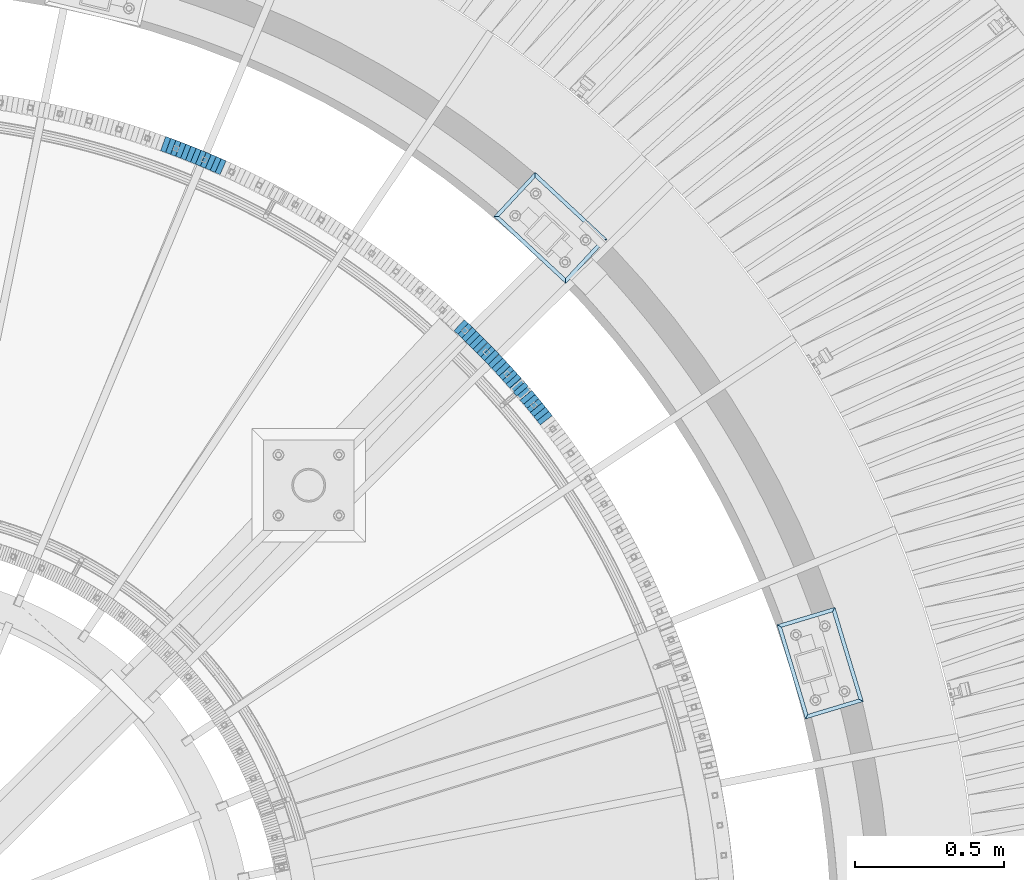
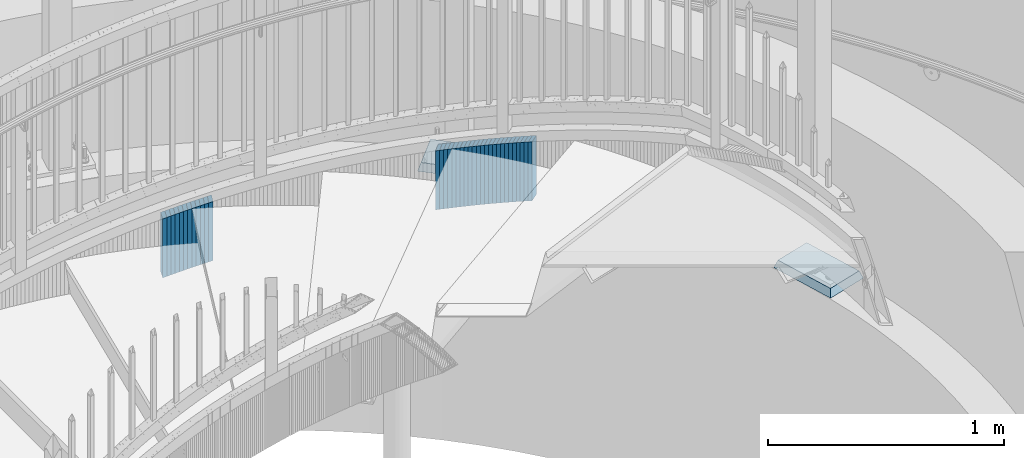
# One storey, part 914 of 975: 38 plates.
"""IFC2X3 building model written with IfcOpenShell, lengths in millimetres."""

from ifc_helpers import new_model, si_unit, frame, origin_with_axes, place, context, subcontext, project, spatial, faceted_brep, material, type_object, element, save


model = new_model("IFC2X3")

# Units and contexts
model_context = context("Model", 3, precision=1e-05, world=origin_with_axes())
body_context = subcontext(model_context, "Body", "Model", "MODEL_VIEW")
ifc_project = project(units=[si_unit("LENGTHUNIT", "METRE", prefix="MILLI"), si_unit("AREAUNIT", "SQUARE_METRE"), si_unit("VOLUMEUNIT", "CUBIC_METRE"), si_unit("MASSUNIT", "GRAM", prefix="KILO"), si_unit("TIMEUNIT", "SECOND"), si_unit("PLANEANGLEUNIT", "RADIAN"), si_unit("SOLIDANGLEUNIT", "STERADIAN"), si_unit("THERMODYNAMICTEMPERATUREUNIT", "DEGREE_CELSIUS"), si_unit("LUMINOUSINTENSITYUNIT", "LUMEN")], contexts=[model_context])

# Site, building, storey
site_placement = place(None, origin_with_axes())
site = spatial("IfcSite", under=ifc_project, at=site_placement, CompositionType="ELEMENT")
building_placement = place(site_placement, origin_with_axes())
building = spatial("IfcBuilding", under=site, at=building_placement, Name="Undefined", CompositionType="ELEMENT")
storey_placement = place(building_placement, origin_with_axes())
storey = spatial("IfcBuildingStorey", under=building, at=storey_placement, Name="Undefined", CompositionType="ELEMENT", Elevation=0.0)

# Plates
ifc_material_1 = material(Name="STEEL/A36")
plate_type_1 = type_object("IfcPlateType", PredefinedType="NOTDEFINED")
plate_1_placement = place(storey_placement, frame((36981.1003536136, 5190.76094105401, 1886.89999999174), z_axis=(0.621276225268784, -0.783591635940412, 7.90051899457469e-11), x_axis=(0.0, 0.0, -1.0)))
element("IfcPlate", 1, at=plate_1_placement, inside=storey, type_object=plate_type_1, material=ifc_material_1, Name="WALL", context=body_context, shape_type="Brep", body=[
    faceted_brep([(0.0, -25.3999999999724, -1.81898940354586e-11), (-5.80000019073486, -25.4000000000524, 17.8675689696865), (-5.80000019073486, 25.4000000000888, 17.867568969803), (0.0, 25.3999999999869, 1.45519152283669e-11), (299.0, -25.4000000000524, 17.8675689696865), (299.0, 25.4000000000888, 17.867568969803), (304.799987792969, -25.3999999999724, -1.81898940354586e-11), (304.799987792969, 25.3999999999869, 1.45519152283669e-11)], [[[0, 1, 2, 3]], [[1, 4, 5, 2]], [[4, 6, 7, 5]], [[6, 0, 3, 7]], [[5, 7, 3, 2]], [[6, 4, 1, 0]]]),
])
plate_2_placement = place(storey_placement, frame((36969.8311938203, 5204.84777914166, 1881.19999999174), z_axis=(0.624695048042231, -0.780868809052785, 0.0), x_axis=(0.0, 0.0, -1.0)))
element("IfcPlate", 2, at=plate_2_placement, inside=storey, type_object=plate_type_1, material=ifc_material_1, Name="WALL", context=body_context, shape_type="Brep", body=[
    faceted_brep([(0.0, -25.3999999999724, -1.81898940354586e-11), (-5.69999980926514, -25.3999999999942, 17.9287471771386), (-5.69999980926514, 25.3999999999796, 17.9287471770876), (0.0, 25.3999999999869, 1.45519152283669e-11), (299.100006103516, -25.3999999999942, 17.9287471771386), (299.100006103516, 25.3999999999796, 17.9287471770876), (304.799987792969, -25.3999999999724, -1.81898940354586e-11), (304.799987792969, 25.3999999999869, 1.45519152283669e-11)], [[[0, 1, 2, 3]], [[1, 4, 5, 2]], [[4, 6, 7, 5]], [[6, 0, 3, 7]], [[5, 7, 3, 2]], [[6, 4, 1, 0]]]),
])
plate_3_placement = place(storey_placement, frame((36958.519161668, 5218.78681468121, 1875.49999999174), z_axis=(0.630168888016676, -0.776458094539445, 2.13421117223333e-10), x_axis=(0.0, 0.0, -1.0)))
element("IfcPlate", 3, at=plate_3_placement, inside=storey, type_object=plate_type_1, material=ifc_material_1, Name="WALL", context=body_context, shape_type="Brep", body=[
    faceted_brep([(0.0, -25.3999999999724, -1.81898940354586e-11), (-5.69999980926514, -25.399999999936, 17.7730140686435), (-5.69999980926514, 25.4000000000487, 17.7730140686363), (0.0, 25.3999999999869, 1.45519152283669e-11), (299.100006103516, -25.399999999936, 17.7730140686435), (299.100006103516, 25.4000000000487, 17.7730140686363), (304.799987792969, -25.3999999999724, -1.81898940354586e-11), (304.799987792969, 25.3999999999869, 1.45519152283669e-11)], [[[0, 1, 2, 3]], [[1, 4, 5, 2]], [[4, 6, 7, 5]], [[6, 0, 3, 7]], [[5, 7, 3, 2]], [[6, 4, 1, 0]]]),
])
plate_4_placement = place(storey_placement, frame((36947.1492950572, 5232.67251838389, 1869.79999999174), z_axis=(0.633543049808969, -0.773707440857816, -1.84472810360603e-11), x_axis=(0.0, 0.0, -1.0)))
element("IfcPlate", 4, at=plate_4_placement, inside=storey, type_object=plate_type_1, material=ifc_material_1, Name="WALL", context=body_context, shape_type="Brep", body=[
    faceted_brep([(0.0, -25.3999999999724, -1.81898940354586e-11), (-5.69999980926514, -25.3999999999614, 17.8370399475461), (-5.69999980926514, 25.4000000000487, 17.8370399475571), (0.0, 25.3999999999869, 1.45519152283669e-11), (299.100006103516, -25.3999999999614, 17.8370399475461), (299.100006103516, 25.4000000000487, 17.8370399475571), (304.799987792969, -25.3999999999724, -1.81898940354586e-11), (304.799987792969, 25.3999999999869, 1.45519152283669e-11)], [[[0, 1, 2, 3]], [[1, 4, 5, 2]], [[4, 6, 7, 5]], [[6, 0, 3, 7]], [[5, 7, 3, 2]], [[6, 4, 1, 0]]]),
])
plate_5_placement = place(storey_placement, frame((36935.4516233755, 5246.6109423738, 1863.99999999174), z_axis=(0.642929821078935, -0.765925091094037, 0.0), x_axis=(0.0, 0.0, -1.0)))
element("IfcPlate", 5, at=plate_5_placement, inside=storey, type_object=plate_type_1, material=ifc_material_1, Name="WALL", context=body_context, shape_type="Brep", body=[
    faceted_brep([(0.0, -25.3999999999724, -1.81898940354586e-11), (-5.80000019073486, -25.4000000000378, 17.8932952880568), (-5.80000019073486, 25.4000000001179, 17.8932952881351), (0.0, 25.3999999999869, 1.45519152283669e-11), (299.0, -25.4000000000378, 17.8932952880568), (299.0, 25.4000000001179, 17.8932952881351), (304.799987792969, -25.3999999999724, -1.81898940354586e-11), (304.799987792969, 25.3999999999869, 1.45519152283669e-11)], [[[0, 1, 2, 3]], [[1, 4, 5, 2]], [[4, 6, 7, 5]], [[6, 0, 3, 7]], [[5, 7, 3, 2]], [[6, 4, 1, 0]]]),
])
plate_6_placement = place(storey_placement, frame((36923.951623377, 5260.31094237226, 1858.29999999174), z_axis=(0.642929821078935, -0.765925091094037, 0.0), x_axis=(0.0, 0.0, -1.0)))
element("IfcPlate", 6, at=plate_6_placement, inside=storey, type_object=plate_type_1, material=ifc_material_1, Name="WALL", context=body_context, shape_type="Brep", body=[
    faceted_brep([(0.0, -25.3999999999724, -1.81898940354586e-11), (-5.69999980926514, -25.4000000000087, 17.8910598754701), (-5.69999980926514, 25.4000000000087, 17.8910598755028), (0.0, 25.3999999999869, 1.45519152283669e-11), (299.100006103516, -25.4000000000087, 17.8910598754701), (299.100006103516, 25.4000000000087, 17.8910598755028), (304.799987792969, -25.3999999999724, -1.81898940354586e-11), (304.799987792969, 25.3999999999869, 1.45519152283669e-11)], [[[0, 1, 2, 3]], [[1, 4, 5, 2]], [[4, 6, 7, 5]], [[6, 0, 3, 7]], [[5, 7, 3, 2]], [[6, 4, 1, 0]]]),
])
plate_7_placement = place(storey_placement, frame((36912.2223084276, 5274.06376871085, 1852.59999999174), z_axis=(0.648946606019702, -0.760833952012862, -4.31282387580723e-12), x_axis=(0.0, 0.0, -1.0)))
element("IfcPlate", 7, at=plate_7_placement, inside=storey, type_object=plate_type_1, material=ifc_material_1, Name="WALL", context=body_context, shape_type="Brep", body=[
    faceted_brep([(0.0, -25.3999999999724, -1.81898940354586e-11), (-5.69999980926514, -25.4000000000233, 17.8807163238162), (-5.69999980926514, 25.400000000096, 17.8807163239253), (0.0, 25.3999999999869, 1.45519152283669e-11), (299.100006103516, -25.4000000000233, 17.8807163238162), (299.100006103516, 25.400000000096, 17.8807163239253), (304.799987792969, -25.3999999999724, -1.81898940354586e-11), (304.799987792969, 25.3999999999869, 1.45519152283669e-11)], [[[0, 1, 2, 3]], [[1, 4, 5, 2]], [[4, 6, 7, 5]], [[6, 0, 3, 7]], [[5, 7, 3, 2]], [[6, 4, 1, 0]]]),
])
plate_8_placement = place(storey_placement, frame((36900.5620830663, 5287.63411760927, 1846.89999999174), z_axis=(0.651716247784782, -0.758462874749533, 0.0), x_axis=(0.0, 0.0, -1.0)))
element("IfcPlate", 8, at=plate_8_placement, inside=storey, type_object=plate_type_1, material=ifc_material_1, Name="WALL", context=body_context, shape_type="Brep", body=[
    faceted_brep([(0.0, -25.3999999999724, -1.81898940354586e-11), (-5.69999980926514, -25.4000000000378, 17.8044929504049), (-5.69999980926514, 25.4000000000233, 17.8044929504613), (0.0, 25.3999999999869, 1.45519152283669e-11), (299.100006103516, -25.4000000000378, 17.8044929504049), (299.100006103516, 25.4000000000233, 17.8044929504613), (304.799987792969, -25.3999999999724, -1.81898940354586e-11), (304.799987792969, 25.3999999999869, 1.45519152283669e-11)], [[[0, 1, 2, 3]], [[1, 4, 5, 2]], [[4, 6, 7, 5]], [[6, 0, 3, 7]], [[5, 7, 3, 2]], [[6, 4, 1, 0]]]),
])
plate_9_placement = place(storey_placement, frame((36888.559604185, 5301.26688626532, 1841.09999999174), z_axis=(0.660880367955666, -0.75049126527281, -6.81784513290041e-11), x_axis=(0.0, 0.0, -1.0)))
element("IfcPlate", 9, at=plate_9_placement, inside=storey, type_object=plate_type_1, material=ifc_material_1, Name="WALL", context=body_context, shape_type="Brep", body=[
    faceted_brep([(0.0, -25.3999999999724, -1.81898940354586e-11), (-5.80000019073486, -25.3999999999869, 17.8549709320232), (-5.80000019073486, 25.3999999999432, 17.8549709319796), (0.0, 25.3999999999869, 1.45519152283669e-11), (299.0, -25.3999999999869, 17.8549709320232), (299.0, 25.3999999999432, 17.8549709319796), (304.799987792969, -25.3999999999724, -1.81898940354586e-11), (304.799987792969, 25.3999999999869, 1.45519152283669e-11)], [[[0, 1, 2, 3]], [[1, 4, 5, 2]], [[4, 6, 7, 5]], [[6, 0, 3, 7]], [[5, 7, 3, 2]], [[6, 4, 1, 0]]]),
])
plate_10_placement = place(storey_placement, frame((36876.5891403825, 5314.74656749097, 1835.39999999174), z_axis=(0.66401742416183, -0.74771709918223, 0.0), x_axis=(0.0, 0.0, -1.0)))
element("IfcPlate", 10, at=plate_10_placement, inside=storey, type_object=plate_type_1, material=ifc_material_1, Name="WALL", context=body_context, shape_type="Brep", body=[
    faceted_brep([(0.0, -25.3999999999724, -1.81898940354586e-11), (-5.69999980926514, -25.4000000000087, 17.9245643615468), (-5.69999980926514, 25.3999999999687, 17.9245643615541), (0.0, 25.3999999999869, 1.45519152283669e-11), (299.100006103516, -25.4000000000087, 17.9245643615468), (299.100006103516, 25.3999999999687, 17.9245643615541), (304.799987792969, -25.3999999999724, -1.81898940354586e-11), (304.799987792969, 25.3999999999869, 1.45519152283669e-11)], [[[0, 1, 2, 3]], [[1, 4, 5, 2]], [[4, 6, 7, 5]], [[6, 0, 3, 7]], [[5, 7, 3, 2]], [[6, 4, 1, 0]]]),
])
plate_11_placement = place(storey_placement, frame((36864.6262554353, 5328.1171143359, 1829.69999999174), z_axis=(0.666794858972905, -0.745241313969713, 0.0), x_axis=(0.0, 0.0, -1.0)))
element("IfcPlate", 11, at=plate_11_placement, inside=storey, type_object=plate_type_1, material=ifc_material_1, Name="WALL", context=body_context, shape_type="Brep", body=[
    faceted_brep([(0.0, -25.3999999999724, -1.81898940354586e-11), (-5.69999980926514, -25.3999999999578, 17.853290557905), (-5.69999980926514, 25.4000000000124, 17.8532905578759), (0.0, 25.3999999999869, 1.45519152283669e-11), (299.100006103516, -25.3999999999578, 17.853290557905), (299.100006103516, 25.4000000000124, 17.8532905578759), (304.799987792969, -25.3999999999724, -1.81898940354586e-11), (304.799987792969, 25.3999999999869, 1.45519152283669e-11)], [[[0, 1, 2, 3]], [[1, 4, 5, 2]], [[4, 6, 7, 5]], [[6, 0, 3, 7]], [[5, 7, 3, 2]], [[6, 4, 1, 0]]]),
])
plate_12_placement = place(storey_placement, frame((36852.320841228, 5341.5439304931, 1823.89999999174), z_axis=(0.675724628879609, -0.737154139868668, 0.0), x_axis=(0.0, 0.0, -1.0)))
element("IfcPlate", 12, at=plate_12_placement, inside=storey, type_object=plate_type_1, material=ifc_material_1, Name="WALL", context=body_context, shape_type="Brep", body=[
    faceted_brep([(0.0, -25.3999999999724, -1.81898940354586e-11), (-5.80000019073486, -25.4000000000415, 17.9067020416005), (-5.80000019073486, 25.3999999999396, 17.9067020415678), (0.0, 25.3999999999869, 1.45519152283669e-11), (299.0, -25.4000000000415, 17.9067020416005), (299.0, 25.3999999999396, 17.9067020415678), (304.799987792969, -25.3999999999724, -1.81898940354586e-11), (304.799987792969, 25.3999999999869, 1.45519152283669e-11)], [[[0, 1, 2, 3]], [[1, 4, 5, 2]], [[4, 6, 7, 5]], [[6, 0, 3, 7]], [[5, 7, 3, 2]], [[6, 4, 1, 0]]]),
])
plate_13_placement = place(storey_placement, frame((36840.1556719854, 5354.71475435396, 1818.19999999174), z_axis=(0.678512969933959, -0.734588421928496, 0.0), x_axis=(0.0, 0.0, -1.0)))
element("IfcPlate", 13, at=plate_13_placement, inside=storey, type_object=plate_type_1, material=ifc_material_1, Name="WALL", context=body_context, shape_type="Brep", body=[
    faceted_brep([(0.0, -25.3999999999724, -1.81898940354586e-11), (-5.69999980926514, -25.4000000000524, 17.8331146239652), (-5.69999980926514, 25.4000000000742, 17.8331146240998), (0.0, 25.3999999999869, 1.45519152283669e-11), (299.100006103516, -25.4000000000524, 17.8331146239652), (299.100006103516, 25.4000000000742, 17.8331146240998), (304.799987792969, -25.3999999999724, -1.81898940354586e-11), (304.799987792969, 25.3999999999869, 1.45519152283669e-11)], [[[0, 1, 2, 3]], [[1, 4, 5, 2]], [[4, 6, 7, 5]], [[6, 0, 3, 7]], [[5, 7, 3, 2]], [[6, 4, 1, 0]]]),
])
plate_14_placement = place(storey_placement, frame((36827.8847926632, 5367.89117626915, 1812.49999999174), z_axis=(0.68152170646267, -0.731797898070369, -1.42942212733033e-10), x_axis=(0.0, 0.0, -1.0)))
element("IfcPlate", 14, at=plate_14_placement, inside=storey, type_object=plate_type_1, material=ifc_material_1, Name="WALL", context=body_context, shape_type="Brep", body=[
    faceted_brep([(0.0, -25.3999999999724, -1.81898940354586e-11), (-5.69999980926514, -25.3999999999578, 17.9047489166387), (-5.69999980926514, 25.3999999999069, 17.9047489165732), (0.0, 25.3999999999869, 1.45519152283669e-11), (299.100006103516, -25.3999999999578, 17.9047489166387), (299.100006103516, 25.3999999999069, 17.9047489165732), (304.799987792969, -25.3999999999724, -1.81898940354586e-11), (304.799987792969, 25.3999999999869, 1.45519152283669e-11)], [[[0, 1, 2, 3]], [[1, 4, 5, 2]], [[4, 6, 7, 5]], [[6, 0, 3, 7]], [[5, 7, 3, 2]], [[6, 4, 1, 0]]]),
])
plate_15_placement = place(storey_placement, frame((36815.4475087859, 5381.03742549032, 1806.69999999174), z_axis=(0.687279550175787, -0.726393020279082, -2.07786001737986e-11), x_axis=(0.0, 0.0, -1.0)))
element("IfcPlate", 15, at=plate_15_placement, inside=storey, type_object=plate_type_1, material=ifc_material_1, Name="WALL", context=body_context, shape_type="Brep", body=[
    faceted_brep([(0.0, -25.3999999999724, -1.81898940354586e-11), (-5.80000019073486, -25.3999999999614, 17.8966484070224), (-5.80000019073486, 25.3999999999105, 17.896648406906), (0.0, 25.3999999999869, 1.45519152283669e-11), (299.0, -25.3999999999614, 17.8966484070224), (299.0, 25.3999999999105, 17.896648406906), (304.799987792969, -25.3999999999724, -1.81898940354586e-11), (304.799987792969, 25.3999999999869, 1.45519152283669e-11)], [[[0, 1, 2, 3]], [[1, 4, 5, 2]], [[4, 6, 7, 5]], [[6, 0, 3, 7]], [[5, 7, 3, 2]], [[6, 4, 1, 0]]]),
])
plate_16_placement = place(storey_placement, frame((36802.9090134557, 5394.08264922902, 1800.99999999174), z_axis=(0.692997020219922, -0.720940448280098, -1.13261080514349e-11), x_axis=(0.0, 0.0, -1.0)))
element("IfcPlate", 16, at=plate_16_placement, inside=storey, type_object=plate_type_1, material=ifc_material_1, Name="WALL", context=body_context, shape_type="Brep", body=[
    faceted_brep([(0.0, -25.3999999999724, -1.81898940354586e-11), (-5.69999980926514, -25.4000000000087, 17.8910598754701), (-5.69999980926514, 25.4000000000087, 17.8910598755028), (0.0, 25.3999999999869, 1.45519152283669e-11), (299.100006103516, -25.4000000000087, 17.8910598754701), (299.100006103516, 25.4000000000087, 17.8910598755028), (304.799987792969, -25.3999999999724, -1.81898940354586e-11), (304.799987792969, 25.3999999999869, 1.45519152283669e-11)], [[[0, 1, 2, 3]], [[1, 4, 5, 2]], [[4, 6, 7, 5]], [[6, 0, 3, 7]], [[5, 7, 3, 2]], [[6, 4, 1, 0]]]),
])
plate_17_placement = place(storey_placement, frame((36790.2693313162, 5407.02681908954, 1795.19999999174), z_axis=(0.698672999155826, -0.715441150794811, 8.11915583653897e-11), x_axis=(0.0, 0.0, -1.0)))
element("IfcPlate", 17, at=plate_17_placement, inside=storey, type_object=plate_type_1, material=ifc_material_1, Name="WALL", context=body_context, shape_type="Brep", body=[
    faceted_brep([(0.0, -25.3999999999724, -1.81898940354586e-11), (-5.80000019073486, -25.4000000000378, 17.8932952880568), (-5.80000019073486, 25.4000000001179, 17.8932952881351), (0.0, 25.3999999999869, 1.45519152283669e-11), (299.0, -25.4000000000378, 17.8932952880568), (299.0, 25.4000000001179, 17.8932952881351), (304.799987792969, -25.3999999999724, -1.81898940354586e-11), (304.799987792969, 25.3999999999869, 1.45519152283669e-11)], [[[0, 1, 2, 3]], [[1, 4, 5, 2]], [[4, 6, 7, 5]], [[6, 0, 3, 7]], [[5, 7, 3, 2]], [[6, 4, 1, 0]]]),
])
plate_18_placement = place(storey_placement, frame((36777.7693313276, 5419.82681909098, 1789.49999999174), z_axis=(0.698672999155826, -0.715441150794811, 8.11915583653897e-11), x_axis=(0.0, 0.0, -1.0)))
element("IfcPlate", 18, at=plate_18_placement, inside=storey, type_object=plate_type_1, material=ifc_material_1, Name="WALL", context=body_context, shape_type="Brep", body=[
    faceted_brep([(0.0, -25.3999999999724, -1.81898940354586e-11), (-5.69999980926514, -25.4000000000087, 17.8910598754701), (-5.69999980926514, 25.4000000000087, 17.8910598755028), (0.0, 25.3999999999869, 1.45519152283669e-11), (299.100006103516, -25.4000000000087, 17.8910598754701), (299.100006103516, 25.4000000000087, 17.8910598755028), (304.799987792969, -25.3999999999724, -1.81898940354586e-11), (304.799987792969, 25.3999999999869, 1.45519152283669e-11)], [[[0, 1, 2, 3]], [[1, 4, 5, 2]], [[4, 6, 7, 5]], [[6, 0, 3, 7]], [[5, 7, 3, 2]], [[6, 4, 1, 0]]]),
])
plate_19_placement = place(storey_placement, frame((36764.857638324, 5432.74103715766, 1783.79999999174), z_axis=(0.707106781186513, -0.707106781186582, 3.1377567211166e-14), x_axis=(0.0, 0.0, -1.0)))
element("IfcPlate", 19, at=plate_19_placement, inside=storey, type_object=plate_type_1, material=ifc_material_1, Name="WALL", context=body_context, shape_type="Brep", body=[
    faceted_brep([(0.0, -25.3999999999724, -1.81898940354586e-11), (-5.69999980926514, -25.3999999999905, 17.9605121612622), (-5.69999980926514, 25.3999999999542, 17.9605121611967), (0.0, 25.3999999999869, 1.45519152283669e-11), (299.100006103516, -25.3999999999905, 17.9605121612622), (299.100006103516, 25.3999999999542, 17.9605121611967), (304.799987792969, -25.3999999999724, -1.81898940354586e-11), (304.799987792969, 25.3999999999869, 1.45519152283669e-11)], [[[0, 1, 2, 3]], [[1, 4, 5, 2]], [[4, 6, 7, 5]], [[6, 0, 3, 7]], [[5, 7, 3, 2]], [[6, 4, 1, 0]]]),
])
plate_20_placement = place(storey_placement, frame((36752.0865084337, 5445.41188647296, 1777.99999999174), z_axis=(0.709896124257809, -0.704306391255782, 0.0), x_axis=(0.0, 0.0, -1.0)))
element("IfcPlate", 20, at=plate_20_placement, inside=storey, type_object=plate_type_1, material=ifc_material_1, Name="WALL", context=body_context, shape_type="Brep", body=[
    faceted_brep([(0.0, -25.3999999999724, -1.81898940354586e-11), (-5.80000019073486, -25.4000000000378, 17.8932952880568), (-5.80000019073486, 25.4000000001179, 17.8932952881351), (0.0, 25.3999999999869, 1.45519152283669e-11), (299.0, -25.4000000000378, 17.8932952880568), (299.0, 25.4000000001179, 17.8932952881351), (304.799987792969, -25.3999999999724, -1.81898940354586e-11), (304.799987792969, 25.3999999999869, 1.45519152283669e-11)], [[[0, 1, 2, 3]], [[1, 4, 5, 2]], [[4, 6, 7, 5]], [[6, 0, 3, 7]], [[5, 7, 3, 2]], [[6, 4, 1, 0]]]),
])
plate_21_placement = place(storey_placement, frame((36739.2156646083, 5458.08189737151, 1772.19999999174), z_axis=(0.712652459251016, -0.701517264451473, -3.59879322786582e-10), x_axis=(0.0, 0.0, -1.0)))
element("IfcPlate", 21, at=plate_21_placement, inside=storey, type_object=plate_type_1, material=ifc_material_1, Name="WALL", context=body_context, shape_type="Brep", body=[
    faceted_brep([(0.0, -25.3999999999724, -1.81898940354586e-11), (-5.80000019073486, -25.3999999999578, 17.9610691070775), (-5.80000019073486, 25.3999999999578, 17.9610691070084), (0.0, 25.3999999999869, 1.45519152283669e-11), (299.0, -25.3999999999578, 17.9610691070775), (299.0, 25.3999999999578, 17.9610691070084), (304.799987792969, -25.3999999999724, -1.81898940354586e-11), (304.799987792969, 25.3999999999869, 1.45519152283669e-11)], [[[0, 1, 2, 3]], [[1, 4, 5, 2]], [[4, 6, 7, 5]], [[6, 0, 3, 7]], [[5, 7, 3, 2]], [[6, 4, 1, 0]]]),
])
for number, where, z_axis, x_axis, name in (
    (22, (36726.3434202649, 5470.65273014973, 1766.49999999174), (0.715441150794838, -0.698672999155798, -8.11802465250365e-11), (0.0, 0.0, -1.0), "WALL"),
    (23, (36713.2992504058, 5483.19241230313, 1760.79999999174), (0.720940448255459, -0.692997020245554, 0.0), (0.0, 0.0, -1.0), "WALL"),
):
    element("IfcPlate", number, at=place(storey_placement, frame(where, z_axis=z_axis, x_axis=x_axis)), inside=storey, type_object=plate_type_1, material=ifc_material_1, Name=name, context=body_context, shape_type="Brep", body=[
        faceted_brep([(0.0, -25.3999999999724, -1.81898940354586e-11), (-5.69999980926514, -25.4000000000087, 17.8910598754701), (-5.69999980926514, 25.4000000000087, 17.8910598755028), (0.0, 25.3999999999869, 1.45519152283669e-11), (299.100006103516, -25.4000000000087, 17.8910598754701), (299.100006103516, 25.4000000000087, 17.8910598755028), (304.799987792969, -25.3999999999724, -1.81898940354586e-11), (304.799987792969, 25.3999999999869, 1.45519152283669e-11)], [[[0, 1, 2, 3]], [[1, 4, 5, 2]], [[4, 6, 7, 5]], [[6, 0, 3, 7]], [[5, 7, 3, 2]], [[6, 4, 1, 0]]]),
    ])
plate_22_placement = place(storey_placement, frame((36700.1540266557, 5495.6309076329, 1754.99999999174), z_axis=(0.726393020279012, -0.687279550175862, 2.07463699553046e-11), x_axis=(0.0, 0.0, -1.0)))
element("IfcPlate", 24, at=plate_22_placement, inside=storey, type_object=plate_type_1, material=ifc_material_1, Name="WALL", context=body_context, shape_type="Brep", body=[
    faceted_brep([(0.0, -25.3999999999724, -1.81898940354586e-11), (-5.80000019073486, -25.3999999999614, 17.8966484070224), (-5.80000019073486, 25.3999999999105, 17.896648406906), (0.0, 25.3999999999869, 1.45519152283669e-11), (299.0, -25.3999999999614, 17.8966484070224), (299.0, 25.3999999999105, 17.896648406906), (304.799987792969, -25.3999999999724, -1.81898940354586e-11), (304.799987792969, 25.3999999999869, 1.45519152283669e-11)], [[[0, 1, 2, 3]], [[1, 4, 5, 2]], [[4, 6, 7, 5]], [[6, 0, 3, 7]], [[5, 7, 3, 2]], [[6, 4, 1, 0]]]),
])
plate_23_placement = place(storey_placement, frame((35891.607673502, 6030.63788327905, 1445.39999999174), z_axis=(0.91564403017333, -0.401990062076094, 0.0), x_axis=(0.0, 0.0, -1.0)))
element("IfcPlate", 25, at=plate_23_placement, inside=storey, type_object=plate_type_1, material=ifc_material_1, Name="WALL", context=body_context, shape_type="Brep", body=[
    faceted_brep([(0.0, -25.3999999999724, -1.81898940354586e-11), (-5.69999980926514, -25.4000000000524, 17.9134025573221), (-5.69999980926514, 25.4000000000524, 17.9134025574494), (0.0, 25.3999999999869, 1.45519152283669e-11), (299.100006103516, -25.4000000000524, 17.9134025573221), (299.100006103516, 25.4000000000524, 17.9134025574494), (304.799987792969, -25.3999999999724, -1.81898940354586e-11), (304.799987792969, 25.3999999999869, 1.45519152283669e-11)], [[[0, 1, 2, 3]], [[1, 4, 5, 2]], [[4, 6, 7, 5]], [[6, 0, 3, 7]], [[5, 7, 3, 2]], [[6, 4, 1, 0]]]),
])
plate_24_placement = place(storey_placement, frame((35875.2076735048, 6037.83788328043, 1439.59999999174), z_axis=(0.91564403017333, -0.401990062076094, 0.0), x_axis=(0.0, 0.0, -1.0)))
element("IfcPlate", 26, at=plate_24_placement, inside=storey, type_object=plate_type_1, material=ifc_material_1, Name="WALL", context=body_context, shape_type="Brep", body=[
    faceted_brep([(0.0, -25.3999999999724, -1.81898940354586e-11), (-5.80000019073486, -25.4000000000415, 17.9067020416005), (-5.80000019073486, 25.3999999999396, 17.9067020415678), (0.0, 25.3999999999869, 1.45519152283669e-11), (299.0, -25.4000000000415, 17.9067020416005), (299.0, 25.3999999999396, 17.9067020415678), (304.799987792969, -25.3999999999724, -1.81898940354586e-11), (304.799987792969, 25.3999999999869, 1.45519152283669e-11)], [[[0, 1, 2, 3]], [[1, 4, 5, 2]], [[4, 6, 7, 5]], [[6, 0, 3, 7]], [[5, 7, 3, 2]], [[6, 4, 1, 0]]]),
])
for number, where, z_axis, x_axis, name in (
    (27, (35858.4170920382, 6044.96330217391, 1433.89999999174), (0.920581781842572, -0.390549846933213, 0.0), (0.0, 0.0, -1.0), "WALL"),
    (28, (35841.9170920362, 6051.96330217498, 1428.19999999174), (0.920581781842572, -0.390549846933213, 0.0), (0.0, 0.0, -1.0), "WALL"),
):
    element("IfcPlate", number, at=place(storey_placement, frame(where, z_axis=z_axis, x_axis=x_axis)), inside=storey, type_object=plate_type_1, material=ifc_material_1, Name=name, context=body_context, shape_type="Brep", body=[
        faceted_brep([(0.0, -25.3999999999724, -1.81898940354586e-11), (-5.69999980926514, -25.4000000000087, 17.9245643615468), (-5.69999980926514, 25.3999999999687, 17.9245643615541), (0.0, 25.3999999999869, 1.45519152283669e-11), (299.100006103516, -25.4000000000087, 17.9245643615468), (299.100006103516, 25.3999999999687, 17.9245643615541), (304.799987792969, -25.3999999999724, -1.81898940354586e-11), (304.799987792969, 25.3999999999869, 1.45519152283669e-11)], [[[0, 1, 2, 3]], [[1, 4, 5, 2]], [[4, 6, 7, 5]], [[6, 0, 3, 7]], [[5, 7, 3, 2]], [[6, 4, 1, 0]]]),
    ])
for number, where, z_axis, x_axis, name in (
    (29, (35825.0254258236, 6058.88490410552, 1422.39999999174), (0.925369259230161, -0.379066925584154, 2.88076535071014e-10), (0.0, 0.0, -1.0), "WALL"),
    (30, (35808.4254258239, 6065.68490410598, 1416.59999999174), (0.925369259230161, -0.379066925584154, 2.88076535071014e-10), (0.0, 0.0, -1.0), "WALL"),
):
    element("IfcPlate", number, at=place(storey_placement, frame(where, z_axis=z_axis, x_axis=x_axis)), inside=storey, type_object=plate_type_1, material=ifc_material_1, Name=name, context=body_context, shape_type="Brep", body=[
        faceted_brep([(0.0, -25.3999999999724, -1.81898940354586e-11), (-5.80000019073486, -25.3999999999869, 17.9387855530222), (-5.80000019073486, 25.3999999999469, 17.9387855528548), (0.0, 25.3999999999869, 1.45519152283669e-11), (299.0, -25.3999999999869, 17.9387855530222), (299.0, 25.3999999999469, 17.9387855528548), (304.799987792969, -25.3999999999724, -1.81898940354586e-11), (304.799987792969, 25.3999999999869, 1.45519152283669e-11)], [[[0, 1, 2, 3]], [[1, 4, 5, 2]], [[4, 6, 7, 5]], [[6, 0, 3, 7]], [[5, 7, 3, 2]], [[6, 4, 1, 0]]]),
    ])
plate_25_placement = place(storey_placement, frame((35791.7037951002, 6072.43436199409, 1410.89999999174), z_axis=(0.927316420402317, -0.374278314162379, 0.0), x_axis=(0.0, 0.0, -1.0)))
element("IfcPlate", 31, at=plate_25_placement, inside=storey, type_object=plate_type_1, material=ifc_material_1, Name="WALL", context=body_context, shape_type="Brep", body=[
    faceted_brep([(0.0, -25.3999999999724, -1.81898940354586e-11), (-5.69999980926514, -25.3999999999578, 17.9047489166387), (-5.69999980926514, 25.3999999999069, 17.9047489165732), (0.0, 25.3999999999869, 1.45519152283669e-11), (299.100006103516, -25.3999999999578, 17.9047489166387), (299.100006103516, 25.3999999999069, 17.9047489165732), (304.799987792969, -25.3999999999724, -1.81898940354586e-11), (304.799987792969, 25.3999999999869, 1.45519152283669e-11)], [[[0, 1, 2, 3]], [[1, 4, 5, 2]], [[4, 6, 7, 5]], [[6, 0, 3, 7]], [[5, 7, 3, 2]], [[6, 4, 1, 0]]]),
])
plate_26_placement = place(storey_placement, frame((35774.7101004759, 6079.05078261786, 1405.19999999174), z_axis=(0.931899909597925, -0.362715533843505, 0.0), x_axis=(0.0, 0.0, -1.0)))
element("IfcPlate", 32, at=plate_26_placement, inside=storey, type_object=plate_type_1, material=ifc_material_1, Name="WALL", context=body_context, shape_type="Brep", body=[
    faceted_brep([(0.0, -25.3999999999724, -1.81898940354586e-11), (-5.69999980926514, -25.4000000000087, 17.9245643615468), (-5.69999980926514, 25.3999999999687, 17.9245643615541), (0.0, 25.3999999999869, 1.45519152283669e-11), (299.100006103516, -25.4000000000087, 17.9245643615468), (299.100006103516, 25.3999999999687, 17.9245643615541), (304.799987792969, -25.3999999999724, -1.81898940354586e-11), (304.799987792969, 25.3999999999869, 1.45519152283669e-11)], [[[0, 1, 2, 3]], [[1, 4, 5, 2]], [[4, 6, 7, 5]], [[6, 0, 3, 7]], [[5, 7, 3, 2]], [[6, 4, 1, 0]]]),
])
plate_27_placement = place(storey_placement, frame((35758.0101004716, 6085.55078261603, 1399.39999999174), z_axis=(0.931899909597925, -0.362715533843505, 0.0), x_axis=(0.0, 0.0, -1.0)))
element("IfcPlate", 33, at=plate_27_placement, inside=storey, type_object=plate_type_1, material=ifc_material_1, Name="WALL", context=body_context, shape_type="Brep", body=[
    faceted_brep([(0.0, -25.3999999999724, -1.81898940354586e-11), (-5.80000019073486, -25.3999999999724, 17.9212169647508), (-5.80000019073486, 25.399999999885, 17.9212169646526), (0.0, 25.3999999999869, 1.45519152283669e-11), (299.0, -25.3999999999724, 17.9212169647508), (299.0, 25.399999999885, 17.9212169646526), (304.799987792969, -25.3999999999724, -1.81898940354586e-11), (304.799987792969, 25.3999999999869, 1.45519152283669e-11)], [[[0, 1, 2, 3]], [[1, 4, 5, 2]], [[4, 6, 7, 5]], [[6, 0, 3, 7]], [[5, 7, 3, 2]], [[6, 4, 1, 0]]]),
])
plate_28_placement = place(storey_placement, frame((35741.0624297537, 6091.9456953729, 1393.69999999174), z_axis=(0.93563663233069, -0.352964718124752, 0.0), x_axis=(0.0, 0.0, -1.0)))
element("IfcPlate", 34, at=plate_28_placement, inside=storey, type_object=plate_type_1, material=ifc_material_1, Name="WALL", context=body_context, shape_type="Brep", body=[
    faceted_brep([(0.0, -25.3999999999724, -1.81898940354586e-11), (-5.69999980926514, -25.3999999999578, 17.853290557905), (-5.69999980926514, 25.4000000000124, 17.8532905578759), (0.0, 25.3999999999869, 1.45519152283669e-11), (299.100006103516, -25.3999999999578, 17.853290557905), (299.100006103516, 25.4000000000124, 17.8532905578759), (304.799987792969, -25.3999999999724, -1.81898940354586e-11), (304.799987792969, 25.3999999999869, 1.45519152283669e-11)], [[[0, 1, 2, 3]], [[1, 4, 5, 2]], [[4, 6, 7, 5]], [[6, 0, 3, 7]], [[5, 7, 3, 2]], [[6, 4, 1, 0]]]),
])
plate_29_placement = place(storey_placement, frame((35724.2156613455, 6098.26328601631, 1387.89999999174), z_axis=(0.936329177363565, -0.351123442136337, 0.0), x_axis=(0.0, 0.0, -1.0)))
element("IfcPlate", 35, at=plate_29_placement, inside=storey, type_object=plate_type_1, material=ifc_material_1, Name="WALL", context=body_context, shape_type="Brep", body=[
    faceted_brep([(0.0, -25.3999999999724, -1.81898940354586e-11), (-5.80000019073486, -25.3999999999869, 17.9387855530222), (-5.80000019073486, 25.3999999999469, 17.9387855528548), (0.0, 25.3999999999869, 1.45519152283669e-11), (299.0, -25.3999999999869, 17.9387855530222), (299.0, 25.3999999999469, 17.9387855528548), (304.799987792969, -25.3999999999724, -1.81898940354586e-11), (304.799987792969, 25.3999999999869, 1.45519152283669e-11)], [[[0, 1, 2, 3]], [[1, 4, 5, 2]], [[4, 6, 7, 5]], [[6, 0, 3, 7]], [[5, 7, 3, 2]], [[6, 4, 1, 0]]]),
])
plate_30_placement = place(storey_placement, frame((35707.1659882484, 6104.45542441034, 1382.19999999174), z_axis=(0.939956673199756, -0.341293792072531, 0.0), x_axis=(0.0, 0.0, -1.0)))
element("IfcPlate", 36, at=plate_30_placement, inside=storey, type_object=plate_type_1, material=ifc_material_1, Name="WALL", context=body_context, shape_type="Brep", body=[
    faceted_brep([(0.0, -25.3999999999724, -1.81898940354586e-11), (-5.69999980926514, -25.4000000000524, 17.8734436034756), (-5.69999980926514, 25.4000000000888, 17.8734436035884), (0.0, 25.3999999999869, 1.45519152283669e-11), (299.100006103516, -25.4000000000524, 17.8734436034756), (299.100006103516, 25.4000000000888, 17.8734436035884), (304.799987792969, -25.3999999999724, -1.81898940354586e-11), (304.799987792969, 25.3999999999869, 1.45519152283669e-11)], [[[0, 1, 2, 3]], [[1, 4, 5, 2]], [[4, 6, 7, 5]], [[6, 0, 3, 7]], [[5, 7, 3, 2]], [[6, 4, 1, 0]]]),
])
ifc_material_2 = material(Name="CONCRETE/GROUT")
plate_type_2 = type_object("IfcPlateType", PredefinedType="NOTDEFINED")
for number, where, z_axis, x_axis, name in (
    (37, (37765.9481041931, 4490.7265390949, 1390.65), (0.957369928409554, 0.288864709123642, 0.0), (0.288864709123643, -0.957369928409553, 0.0), "GROUT"),
    (38, (36815.9782617857, 5860.03971906289, 1390.65), (0.68156122113971, 0.73176109614993, 0.0), (0.73176109614993, -0.68156122113971, 0.0), "GROUT"),
):
    element("IfcPlate", number, at=place(storey_placement, frame(where, z_axis=z_axis, x_axis=x_axis)), inside=storey, type_object=plate_type_2, material=ifc_material_2, Name=name, context=body_context, shape_type="Brep", body=[
        faceted_brep([(330.200012367033, 19.0500013667977, 203.199997417756), (1.09139364212751e-11, 19.05, 203.199996948282), (12.7000000020234, -19.0499999844749, 190.500000003405), (317.500000003602, -19.049999999379, 190.499999996773), (330.200012206657, 19.0500004884277, -1.48389517562464e-07), (317.499999999585, -19.0499999999586, 12.6999999966938), (12.6999999980108, -19.0499999989649, 12.7000000033258), (2.63382389675826e-07, 19.0500000000138, 0.0)], [[[0, 1, 2, 3]], [[4, 5, 6, 7]], [[5, 4, 0, 3]], [[6, 5, 3, 2]], [[7, 6, 2, 1]], [[4, 7, 1, 0]]]),
    ])

save(model, "model.ifc")
